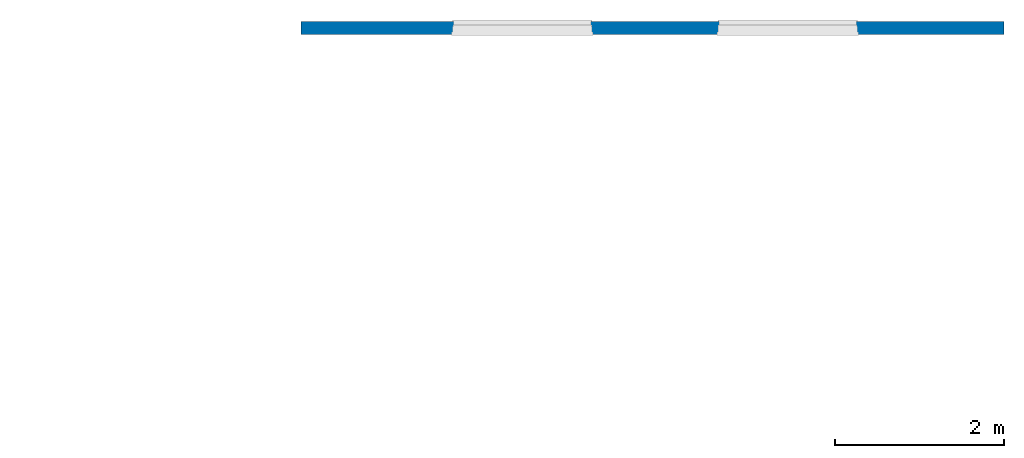
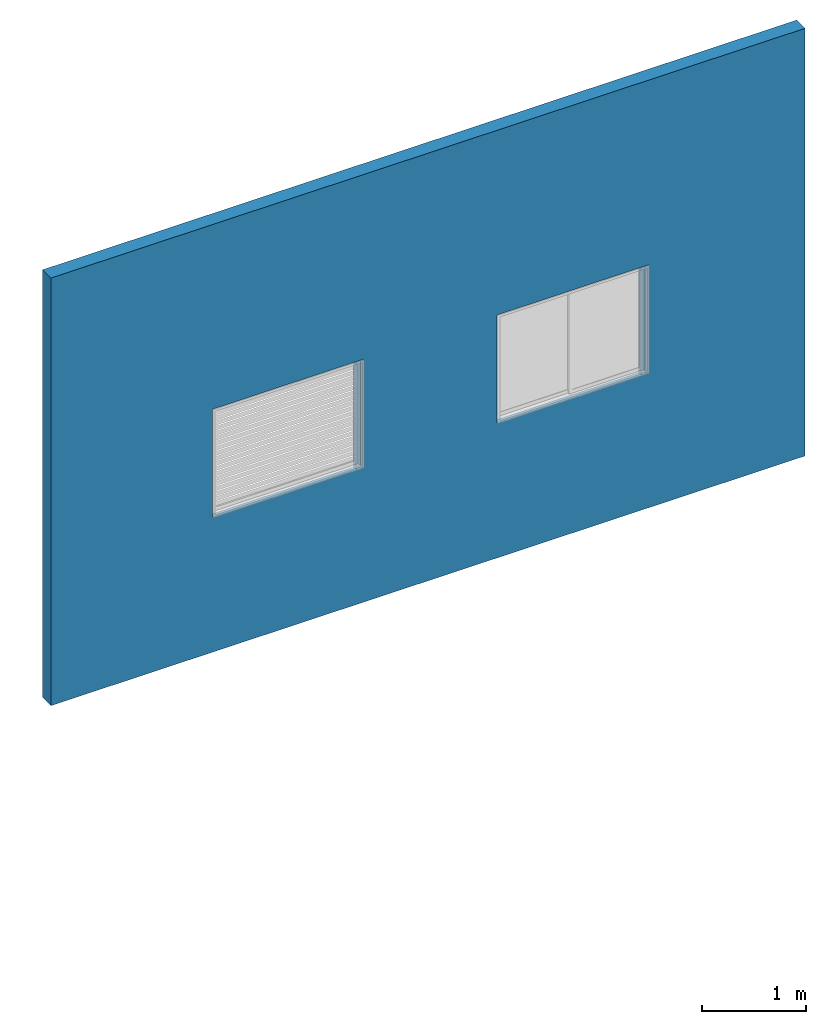
# One storey, part 1 of 3: 1 wall.
"""IFC2X3 building model written with IfcOpenShell, lengths in millimetres."""

import ifcopenshell
import ifcopenshell.guid

model = None  # the IFC model being written
_history = None  # IfcOwnerHistory: only IFC2X3 demands one
_inside = {}  # id of a spatial element -> (the spatial element, [elements in it])
_under = {}  # id of a project, library or spatial element -> (it, [spatial elements below it])
_declared = {}  # id of a project -> (the project, [libraries it declares])
_typed = {}  # id of a type object -> (the type object, [elements of that type])
_made_of = {}  # id of a material, layer set ... -> (it, [elements and type objects made of it])


def new_model(schema):
    """Start an empty IFC model of exactly this schema.

    Asked for "IFC4X3", IfcOpenShell would pick the latest addendum, in which some entities
    have other attributes; the version numbers below select the first issue.
    IFC2X3 requires an IfcOwnerHistory on every rooted entity: one is made here for all.
    """
    global model, _history
    if schema == "IFC4X3":
        model = ifcopenshell.file(schema_version=(4, 3, 0, 0))
    else:
        model = ifcopenshell.file(schema=schema)
    _inside.clear()
    _under.clear()
    _declared.clear()
    _typed.clear()
    _made_of.clear()
    _history = None
    if model.schema == "IFC2X3":
        org = make("IfcOrganization", Name="unknown")
        user = make(
            "IfcPersonAndOrganization",
            ThePerson=make("IfcPerson", FamilyName="unknown"),
            TheOrganization=org,
        )
        app = make(
            "IfcApplication",
            ApplicationDeveloper=org,
            Version="unknown",
            ApplicationFullName="unknown",
            ApplicationIdentifier="unknown",
        )
        _history = make(
            "IfcOwnerHistory",
            OwningUser=user,
            OwningApplication=app,
            ChangeAction="ADDED",
            CreationDate=0,
        )
    return model


def make(cls, **values):
    """One entity of the class cls with the attributes given. An attribute that is None is left unset."""
    return model.create_entity(
        cls, **{name: value for name, value in values.items() if value is not None}
    )


def entity(cls, *values):
    """Any entity or typed value of the class cls, its attributes in the order of the schema. None: left unset."""
    e = model.create_entity(cls)
    for i, value in enumerate(values):
        if value is not None:
            e[i] = value
    return e


def rooted(cls, **values):
    """An entity with a GlobalId (a new one), such as an element, a storey or a relation."""
    return make(cls, GlobalId=ifcopenshell.guid.new(), OwnerHistory=_history, **values)


def si_unit(unit_type, name, prefix=None):
    """IfcSIUnit, for example si_unit("LENGTHUNIT", "METRE", prefix="MILLI")."""
    return make("IfcSIUnit", UnitType=unit_type, Prefix=prefix, Name=name)


def converted_unit(unit_type, name, factor, base, dimensions=None, offset=None):
    """IfcConversionBasedUnit, such as the inch: factor (a typed value) times the base unit."""
    return make(
        "IfcConversionBasedUnit"
        if offset is None
        else "IfcConversionBasedUnitWithOffset",
        ConversionOffset=offset,
        Dimensions=None
        if dimensions is None
        else entity("IfcDimensionalExponents", *dimensions),
        UnitType=unit_type,
        Name=name,
        ConversionFactor=make(
            "IfcMeasureWithUnit", ValueComponent=factor, UnitComponent=base
        ),
    )


def derived_unit(unit_type, elements):
    """IfcDerivedUnit: a product of units, each with its exponent."""
    return make(
        "IfcDerivedUnit",
        Elements=[
            make("IfcDerivedUnitElement", Unit=unit, Exponent=power)
            for unit, power in elements
        ],
        UnitType=unit_type,
    )


def money_unit(currency):
    """IfcMonetaryUnit."""
    return make("IfcMonetaryUnit", Currency=currency)


def assignment(units):
    """IfcUnitAssignment: the units of a project."""
    return None if units is None else make("IfcUnitAssignment", Units=units)


def point(xyz):
    """IfcCartesianPoint."""
    return None if xyz is None else make("IfcCartesianPoint", Coordinates=xyz)


def direction(xyz):
    """IfcDirection."""
    return None if xyz is None else make("IfcDirection", DirectionRatios=xyz)


def frame(location, z_axis=None, x_axis=None):
    """IfcAxis2Placement3D, a coordinate frame: its origin and axes. An axis left out is left unset."""
    return make(
        "IfcAxis2Placement3D",
        Location=point(location),
        Axis=direction(z_axis),
        RefDirection=direction(x_axis),
    )


def origin_with_axes():
    """The frame at (0, 0, 0) with the z axis (0, 0, 1) and the x axis (1, 0, 0) written out."""
    return frame((0.0, 0.0, 0.0), z_axis=(0.0, 0.0, 1.0), x_axis=(1.0, 0.0, 0.0))


def place(relative_to, where):
    """IfcLocalPlacement: puts the frame where relative to a parent placement (None: the world)."""
    return make(
        "IfcLocalPlacement", PlacementRelTo=relative_to, RelativePlacement=where
    )


def context(
    kind, dimensions, precision=None, world=None, true_north=None, identifier=None
):
    """IfcGeometricRepresentationContext, for example the 3D "Model" context."""
    return make(
        "IfcGeometricRepresentationContext",
        ContextIdentifier=identifier,
        ContextType=kind,
        CoordinateSpaceDimension=dimensions,
        Precision=precision,
        WorldCoordinateSystem=world,
        TrueNorth=true_north,
    )


def subcontext(parent, identifier, kind, view, scale=None):
    """IfcGeometricRepresentationSubContext, for example "Body" below "Model"."""
    return make(
        "IfcGeometricRepresentationSubContext",
        ContextIdentifier=identifier,
        ContextType=kind,
        ParentContext=parent,
        TargetScale=scale,
        TargetView=view,
    )


def project(units=None, contexts=None):
    """IfcProject with its units and contexts."""
    return rooted(
        "IfcProject",
        Name="project",
        RepresentationContexts=contexts,
        UnitsInContext=assignment(units),
    )


def spatial(cls, under=None, at=None, **own):
    """A site, building, storey or space (cls), placed at a placement, below another one or the project."""
    s = rooted(cls, ObjectPlacement=at, **own)
    if under is not None:
        _under.setdefault(under.id(), (under, []))[1].append(s)
    return s


def faces_of(points, faces, orient=None, outer=None):
    """IfcFace entities. A face is a list of loops; a loop is a list of indices into points, from 0.

    orient and outer hold one flag for each loop. By default every Orientation is true, the
    first loop of a face is its IfcFaceOuterBound and the others are IfcFaceBound.
    """
    made = []
    for i, loops in enumerate(faces):
        bounds = []
        for j, loop in enumerate(loops):
            is_outer = j == 0 if outer is None else outer[i][j]
            bounds.append(
                make(
                    "IfcFaceOuterBound" if is_outer else "IfcFaceBound",
                    Bound=make("IfcPolyLoop", Polygon=[points[k] for k in loop]),
                    Orientation=True if orient is None else orient[i][j],
                )
            )
        made.append(make("IfcFace", Bounds=bounds))
    return made


def faceted_brep(points, faces, orient=None, outer=None, voids=None):
    """IfcFacetedBrep: a solid bounded by flat faces; with voids (closed shells), ...WithVoids."""
    shared = [point(p) for p in points]
    hull = make("IfcClosedShell", CfsFaces=faces_of(shared, faces, orient, outer))
    if voids is None:
        return make("IfcFacetedBrep", Outer=hull)
    return make(
        "IfcFacetedBrepWithVoids",
        Outer=hull,
        Voids=[
            make(cls, CfsFaces=faces_of(shared, fs, o, b)) for cls, fs, o, b in voids
        ],
    )


def shape(context_of_items, identifier, shape_type, items):
    """IfcShapeRepresentation: the items that make up one representation, for example the "Body"."""
    return make(
        "IfcShapeRepresentation",
        ContextOfItems=context_of_items,
        RepresentationIdentifier=identifier,
        RepresentationType=shape_type,
        Items=items,
    )


def material(Name=None, Category=None):
    """IfcMaterial."""
    return make("IfcMaterial", Name=Name, Category=Category)


def made_of(thing, what):
    """Note that an element or type object is made of a material, layer set ...; save() writes the relation."""
    if what is not None:
        _made_of.setdefault(what.id(), (what, []))[1].append(thing)
    return thing


def type_object(cls, material=None, **own):
    """A type object (cls), such as IfcWallType, which elements share."""
    return made_of(rooted(cls, **own), material)


def element(
    cls,
    number,
    at=None,
    inside=None,
    cuts=None,
    type_object=None,
    material=None,
    context=None,
    identifier="Body",
    shape_type=None,
    held_by="IfcProductDefinitionShape",
    body=None,
    shapes=None,
    **own,
):
    """One element of the class cls, such as IfcWall. Its Tag is "e" and its number.

    at: its placement. inside: the storey or other place that contains it. cuts: it is an
    opening in that element (IfcRelVoidsElement). A single representation is given by context,
    identifier, shape_type and body (its items); several are given by shapes. held_by: the class
    of the entity that holds the representations. save() writes the other relations.
    """
    e = rooted(cls, Tag="e%d" % number, ObjectPlacement=at, **own)
    if body is not None:
        shapes = [shape(context, identifier, shape_type, body)]
    if shapes is not None:
        e.Representation = make(held_by, Representations=shapes)
    if inside is not None:
        _inside.setdefault(inside.id(), (inside, []))[1].append(e)
    if cuts is not None:
        rooted(
            "IfcRelVoidsElement", RelatingBuildingElement=cuts, RelatedOpeningElement=e
        )
    if type_object is not None:
        _typed.setdefault(type_object.id(), (type_object, []))[1].append(e)
    return made_of(e, material)


def aggregate(whole, parts):
    """IfcRelAggregates: a whole, such as a stair, and the parts it consists of."""
    return rooted("IfcRelAggregates", RelatingObject=whole, RelatedObjects=parts)


def save(model, path):
    """Write the relations noted so far, then the file.

    IfcRelAggregates (storeys below a building ...), IfcRelContainedInSpatialStructure (elements
    in a storey), IfcRelDefinesByType, IfcRelAssociatesMaterial and IfcRelDeclares: one each for
    every whole, place, type object, material and project.
    """
    for whole, parts in _under.values():
        aggregate(whole, parts)
    for where, things in _inside.values():
        rooted(
            "IfcRelContainedInSpatialStructure",
            RelatedElements=things,
            RelatingStructure=where,
        )
    for kind, things in _typed.values():
        rooted("IfcRelDefinesByType", RelatedObjects=things, RelatingType=kind)
    for what, things in _made_of.values():
        rooted("IfcRelAssociatesMaterial", RelatedObjects=things, RelatingMaterial=what)
    for by, libraries in _declared.values():
        rooted("IfcRelDeclares", RelatingContext=by, RelatedDefinitions=libraries)
    model.write(path)


model = new_model("IFC2X3")

# Units and contexts
model_context = context("Model", 3, precision=1e-05, world=origin_with_axes(), true_north=direction((0.0, 1.0)))
body_context = subcontext(model_context, "Body", "Model", "MODEL_VIEW")
ifc_project = project(units=[si_unit("LENGTHUNIT", "METRE", prefix="MILLI"), si_unit("AREAUNIT", "SQUARE_METRE"), si_unit("VOLUMEUNIT", "CUBIC_METRE"), converted_unit("PLANEANGLEUNIT", "DEGREE", entity("IfcPlaneAngleMeasure", 0.0174532925199), si_unit("PLANEANGLEUNIT", "RADIAN"), dimensions=[0, 0, 0, 0, 0, 0, 0]), si_unit("SOLIDANGLEUNIT", "STERADIAN"), money_unit("JPY"), converted_unit("TIMEUNIT", "Year", entity("IfcTimeMeasure", 31556926.0), si_unit("TIMEUNIT", "SECOND"), dimensions=[0, 0, 1, 0, 0, 0, 0]), si_unit("MASSUNIT", "GRAM", prefix="KILO"), si_unit("THERMODYNAMICTEMPERATUREUNIT", "DEGREE_CELSIUS"), si_unit("LUMINOUSINTENSITYUNIT", "LUMEN"), si_unit("ENERGYUNIT", "JOULE", prefix="MEGA"), derived_unit("THERMALCONDUCTANCEUNIT", [(si_unit("POWERUNIT", "WATT"), 1), (si_unit("LENGTHUNIT", "METRE"), -1), (si_unit("THERMODYNAMICTEMPERATUREUNIT", "KELVIN"), -1)]), derived_unit("SPECIFICHEATCAPACITYUNIT", [(si_unit("ENERGYUNIT", "JOULE"), 1), (si_unit("MASSUNIT", "GRAM", prefix="KILO"), -1), (si_unit("THERMODYNAMICTEMPERATUREUNIT", "KELVIN"), -1)]), derived_unit("MASSDENSITYUNIT", [(si_unit("MASSUNIT", "GRAM", prefix="KILO"), 1), (si_unit("VOLUMEUNIT", "CUBIC_METRE"), -1)])], contexts=[model_context])

# Site, building, storey
site_placement = place(None, origin_with_axes())
site = spatial("IfcSite", under=ifc_project, at=site_placement, CompositionType="ELEMENT")
building_placement = place(site_placement, origin_with_axes())
building = spatial("IfcBuilding", under=site, at=building_placement, CompositionType="ELEMENT")
storey_placement = place(building_placement, origin_with_axes())
storey = spatial("IfcBuildingStorey", under=building, at=storey_placement, Name="1FL", CompositionType="ELEMENT", Elevation=0.0)

# Wall
ifc_material = material()
wall_type = type_object("IfcWallType", PredefinedType="NOTDEFINED")
wall_placement = place(storey_placement, frame((-5941.57280091, -2483.59976003, 0.0), z_axis=(0.0, 0.0, 1.0), x_axis=(1.0, 0.0, 0.0)))
element("IfcWall", 1, at=wall_placement, inside=storey, type_object=wall_type, material=ifc_material, Name="W1", context=body_context, shape_type="Brep", body=[
    faceted_brep([(8341.32028987, -80.0, 5000.0), (0.0, -80.0, 5000.0), (0.0, -80.0, 0.0), (8341.32028987, -80.0, 0.0), (1784.44022776, -80.0, 2840.0), (3464.44022776, -80.0, 2840.0), (3464.44022776, -80.0, 1575.0), (1784.44022776, -80.0, 1575.0), (4934.52357342, -80.0, 1575.0), (4934.52357342, -80.0, 2840.0), (6614.52357342, -80.0, 2840.0), (6614.52357342, -80.0, 1575.0), (8341.32028987, 80.0, 5000.0), (0.0, 80.0, 5000.0), (0.0, 80.0, 0.0), (8341.32028987, 80.0, 0.0), (3464.44022776, -79.0, 2840.0), (1784.44022776, -79.0, 2840.0), (3464.44022776, -79.0, 1575.0), (1784.44022776, -79.0, 1575.0), (4934.52357342, -79.0, 1575.0), (4934.52357342, -79.0, 2840.0), (6614.52357342, -79.0, 2840.0), (6614.52357342, -79.0, 1575.0), (3439.44022776, 80.0, 1490.0), (3439.44022776, 80.0, 2815.0), (1809.44022776, 80.0, 2815.0), (1809.44022776, 80.0, 1490.0), (4959.52357342, 80.0, 1490.0), (6589.52357342, 80.0, 1490.0), (6589.52357342, 80.0, 2815.0), (4959.52357342, 80.0, 2815.0), (3439.44022776, -79.0, 1510.0), (1809.44022776, -79.0, 1510.0), (1764.44022776, -79.0, 1510.0), (1764.44022776, -79.0, 2860.0), (3484.44022776, -79.0, 2860.0), (3484.44022776, -79.0, 1510.0), (4914.52357342, -79.0, 2860.0), (6634.52357342, -79.0, 2860.0), (6634.52357342, -79.0, 1510.0), (6589.52357342, -79.0, 1510.0), (4959.52357342, -79.0, 1510.0), (4914.52357342, -79.0, 1510.0), (3439.44022776, 35.0, 1510.0), (3439.44022776, 35.0, 2815.0), (1809.44022776, 35.0, 2815.0), (1809.44022776, 35.0, 1510.0), (6589.52357342, 35.0, 2815.0), (6589.52357342, 35.0, 1510.0), (4959.52357342, 35.0, 2815.0), (4959.52357342, 35.0, 1510.0), (1779.41022776, 34.99, 1510.0), (1764.44022776, 30.0, 1510.0), (1764.44022776, 30.0, 2860.0), (3484.44022776, 30.0, 2860.0), (3484.44022776, 30.0, 1510.0), (3469.44022776, 35.0, 1510.0), (6634.52357342, 30.0, 2860.0), (4914.52357342, 30.0, 2860.0), (6634.52357342, 30.0, 1510.0), (6619.55357342, 34.99, 1510.0), (6619.52357342, 34.99, 1510.0), (6619.52357342, 35.0, 1510.0), (4914.52357342, 30.0, 1510.0), (4929.52357342, 35.0, 1510.0), (4929.52357342, 34.99, 1510.0), (4929.49357342, 34.99, 1510.0), (3469.44022776, 35.0, 2845.0), (1779.44022776, 34.99, 2845.0), (6619.52357342, 35.0, 2845.0), (4929.52357342, 35.0, 2845.0), (6619.55357342, 34.99, 2845.0), (6619.52357342, 34.99, 2845.0), (4929.52357342, 34.99, 2845.0), (4929.49357342, 34.99, 2845.0)], [[[0, 1, 2, 3], [4, 5, 6, 7], [8, 9, 10, 11]], [[12, 13, 1, 0]], [[2, 1, 13, 14]], [[3, 2, 14, 15]], [[12, 0, 3, 15]], [[16, 5, 4, 17]], [[18, 6, 5, 16]], [[19, 7, 6, 18]], [[17, 4, 7, 19]], [[20, 21, 9, 8]], [[21, 22, 10, 9]], [[22, 23, 11, 10]], [[23, 20, 8, 11]], [[15, 14, 13, 12], [24, 25, 26, 27], [28, 29, 30, 31]], [[32, 33, 34, 35, 36, 37], [18, 16, 17, 19]], [[38, 39, 40, 41, 42, 43], [20, 23, 22, 21]], [[32, 44, 45, 25, 24]], [[45, 46, 26, 25]], [[33, 27, 26, 46, 47]], [[27, 33, 32, 24]], [[29, 28, 42, 41]], [[48, 30, 29, 41, 49]], [[30, 48, 50, 31]], [[31, 50, 51, 42, 28]], [[33, 47, 52, 53, 34]], [[34, 53, 54, 35]], [[36, 35, 54, 55]], [[37, 36, 55, 56]], [[37, 56, 57, 44, 32]], [[58, 39, 38, 59]], [[60, 40, 39, 58]], [[49, 41, 40, 60, 61, 62, 63]], [[64, 43, 42, 51, 65, 66, 67]], [[38, 43, 64, 59]], [[68, 46, 45, 44, 57]], [[52, 47, 46, 69]], [[63, 70, 71, 65, 51, 50, 48, 49]], [[54, 53, 52, 69]], [[69, 68, 55, 54]], [[55, 68, 57, 56]], [[59, 71, 70, 58]], [[70, 72, 61, 60, 58]], [[72, 73, 62, 61]], [[62, 73, 70, 63]], [[65, 71, 74, 66]], [[75, 67, 66, 74]], [[67, 75, 71, 59, 64]], [[69, 46, 68]], [[73, 72, 70]], [[75, 74, 71]]]),
])

save(model, "model.ifc")
